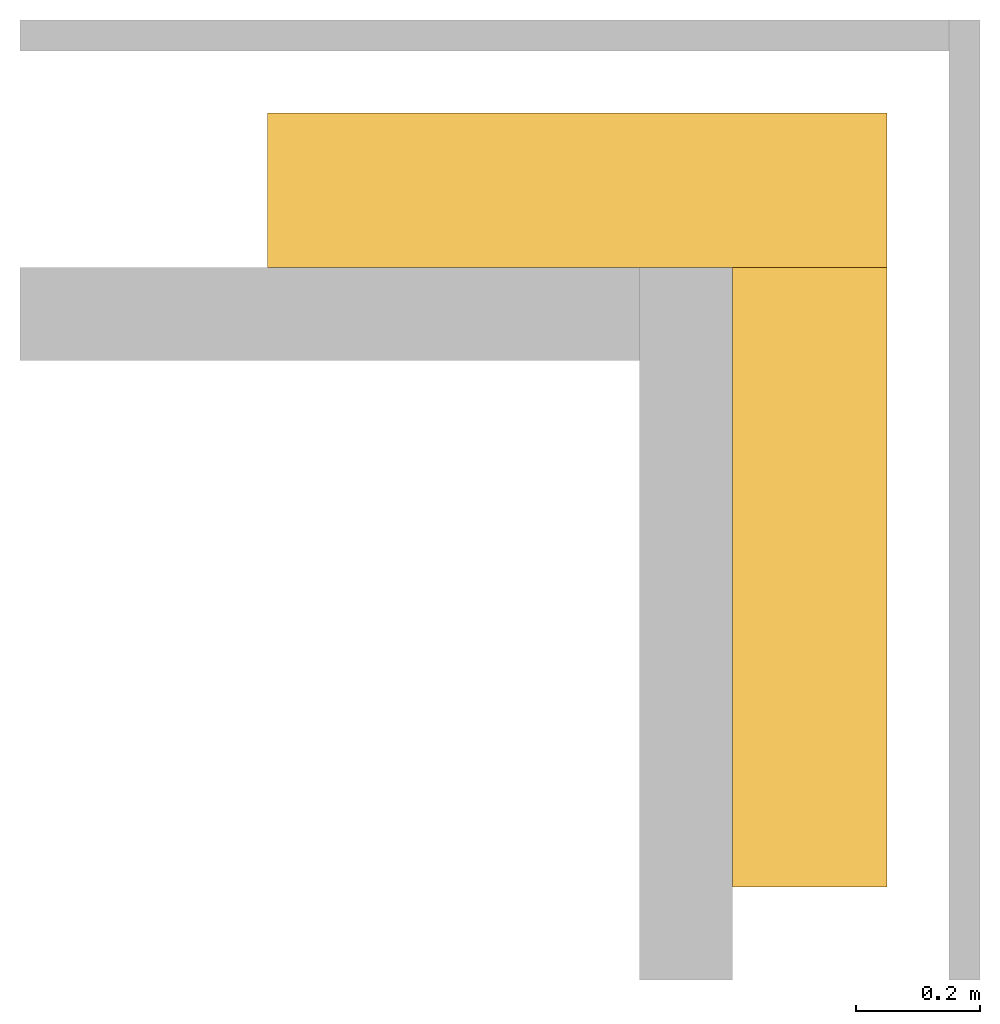
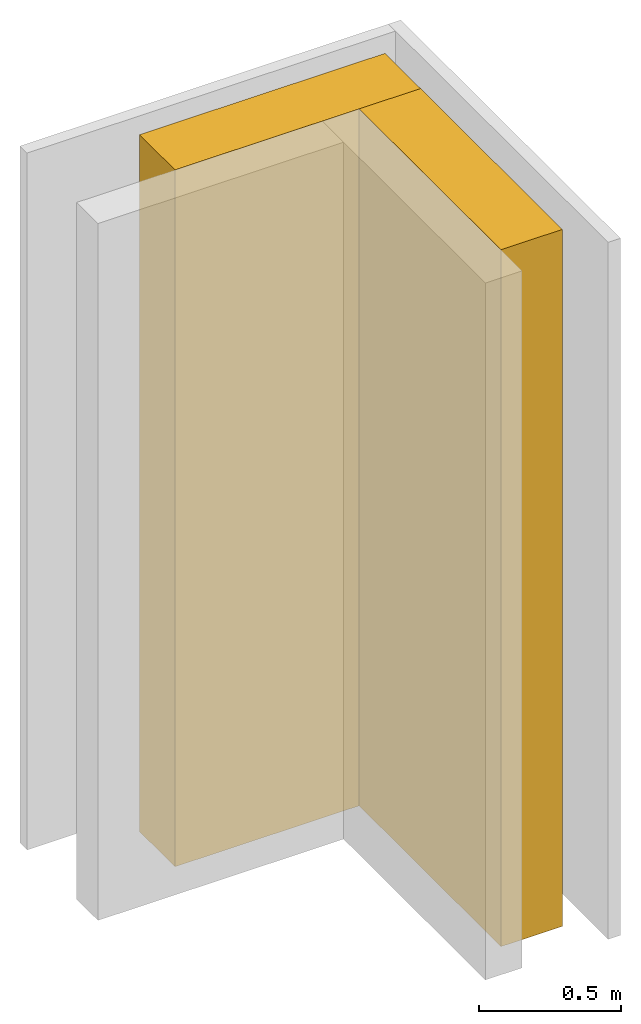
# One storey, part 2 of 2: 2 coverings.
"""IFC4 building model written with IfcOpenShell, lengths in metres."""

from ifc_helpers import new_model, entity, si_unit, converted_unit, frame, frame_2d, origin_with_axes, place, context, subcontext, project, spatial, indexed_curve, outline, extrude, material, layer, layer_set, layer_usage, type_object, element, save


model = new_model("IFC4")

# Units and contexts
model_context = context("Model", 3, precision=1e-05, world=origin_with_axes())
plan_context = context("Plan", 2, precision=1e-05, world=frame_2d((0.0, 0.0, 0.0), x_axis=(1.0, 0.0, 0.0)))
context_of_model = context(None, 3, precision=1e-05, world=origin_with_axes())
body_context = subcontext(model_context, "Body", "Model", "MODEL_VIEW")
ifc_project = project(units=[si_unit("VOLUMEUNIT", "CUBIC_METRE"), si_unit("LENGTHUNIT", "METRE"), converted_unit("PLANEANGLEUNIT", "degree", entity("IfcReal", 0.0174532925199433), si_unit("PLANEANGLEUNIT", "RADIAN"), dimensions=[0, 0, 0, 0, 0, 0, 0]), si_unit("AREAUNIT", "SQUARE_METRE")], contexts=[model_context, plan_context, context_of_model])

# Site, building, storey
site_placement = place(None, origin_with_axes())
site = spatial("IfcSite", under=ifc_project, at=site_placement)
building_placement = place(site_placement, origin_with_axes())
building = spatial("IfcBuilding", under=site, at=building_placement, Name="Building")
storey_placement = place(building_placement, origin_with_axes())
storey = spatial("IfcBuildingStorey", under=building, at=storey_placement, Name="Storey")

# Coverings
ifc_material = material(Name="Material.001")
ifc_layer = layer(ifc_material, 0.25, ventilated=False, Priority=0)
ifc_layer_set = layer_set([ifc_layer], Name="crosshatch3")
ifc_layer_usage_1 = layer_usage(ifc_layer_set, "AXIS2", "POSITIVE", 0.0)
covering_type = type_object("IfcCoveringType", Name="insulation_250mm", PredefinedType="NOTDEFINED", material=ifc_layer_set)
covering_1_placement = place(storey_placement, frame((0.400000005960464, 3.87430191040039e-07, -7.45058059692383e-08), z_axis=(0.0, 0.0, 1.0), x_axis=(-1.0, 3.89414367418794e-07, 0.0)))
element("IfcCovering", 1, at=covering_1_placement, inside=storey, type_object=covering_type, material=ifc_layer_usage_1, Name="insulation_250mm", PredefinedType="NOTDEFINED", context=body_context, shape_type="SweptSolid", body=[
    extrude(outline(indexed_curve([(0.0, 0.0), (0.0, 0.25), (1.0, 0.25), (1.0, 0.0), (0.0, 0.0)], self_intersect=False)), origin_with_axes(), (0.0, 0.0, 1.0), 3.0),
])
ifc_layer_usage_2 = layer_usage(ifc_layer_set, "AXIS2", "POSITIVE", 0.0)
covering_2_placement = place(storey_placement, frame((0.149999916553497, -0.249999612569809, -7.45058059692383e-08), z_axis=(0.0, 0.0, 1.0), x_axis=(1.19248806385031e-08, -1.0, 0.0)))
element("IfcCovering", 2, at=covering_2_placement, inside=storey, type_object=covering_type, material=ifc_layer_usage_2, Name="insulation_250mm", PredefinedType="NOTDEFINED", context=body_context, shape_type="SweptSolid", body=[
    extrude(outline(indexed_curve([(0.0, 0.0), (0.0, 0.25), (1.0, 0.25), (1.0, 0.0), (0.0, 0.0)], self_intersect=False)), origin_with_axes(), (0.0, 0.0, 1.0), 3.0),
])

save(model, "model.ifc")
